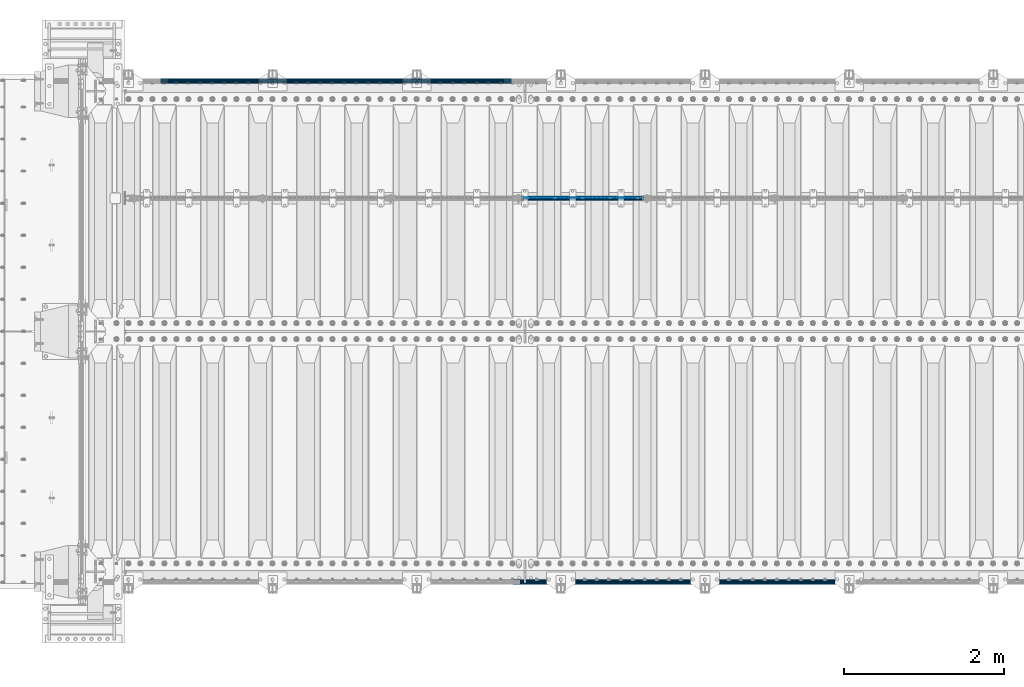
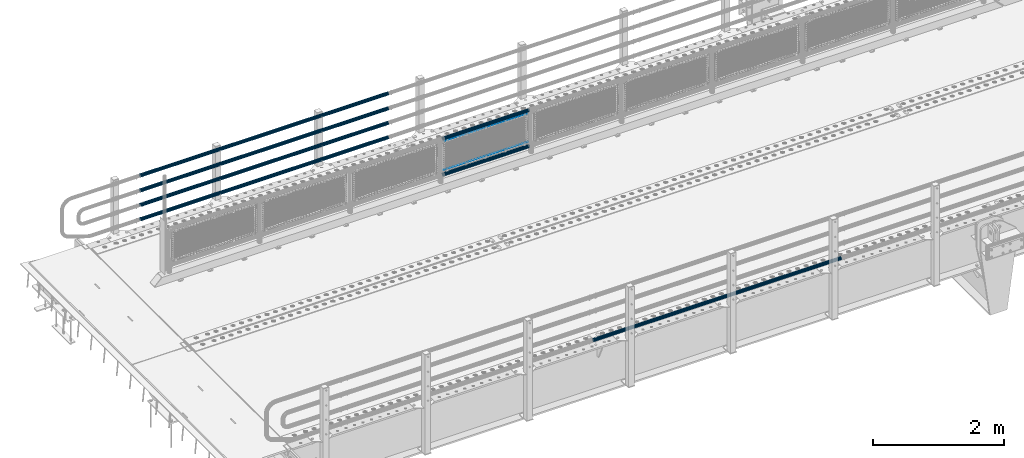
# One storey, part 97 of 208: 9 beams.
"""IFC2X3 building model written with IfcOpenShell, lengths in millimetres."""

from ifc_helpers import new_model, si_unit, frame, origin_with_axes, place, context, subcontext, project, spatial, faceted_brep, material, type_object, element, save


model = new_model("IFC2X3")

# Units and contexts
model_context = context("Model", 3, precision=1e-05, world=origin_with_axes())
body_context = subcontext(model_context, "Body", "Model", "MODEL_VIEW")
ifc_project = project(units=[si_unit("LENGTHUNIT", "METRE", prefix="MILLI"), si_unit("AREAUNIT", "SQUARE_METRE"), si_unit("VOLUMEUNIT", "CUBIC_METRE"), si_unit("MASSUNIT", "GRAM", prefix="KILO"), si_unit("TIMEUNIT", "SECOND"), si_unit("PLANEANGLEUNIT", "RADIAN"), si_unit("SOLIDANGLEUNIT", "STERADIAN"), si_unit("THERMODYNAMICTEMPERATUREUNIT", "DEGREE_CELSIUS"), si_unit("LUMINOUSINTENSITYUNIT", "LUMEN")], contexts=[model_context])

# Site, building, storey
site_placement = place(None, origin_with_axes())
site = spatial("IfcSite", under=ifc_project, at=site_placement, CompositionType="ELEMENT")
building_placement = place(site_placement, origin_with_axes())
building = spatial("IfcBuilding", under=site, at=building_placement, Name="Standard", CompositionType="ELEMENT")
storey_placement = place(building_placement, origin_with_axes())
storey = spatial("IfcBuildingStorey", under=building, at=storey_placement, Name="Undefined", CompositionType="ELEMENT", Elevation=0.0)

# Beams
ifc_material_1 = material(Name="Misc_Undefined")
beam_type_1 = type_object("IfcBeamType", Name="D3", PredefinedType="NOTDEFINED")
beam_1_placement = place(storey_placement, frame((-36974.0, 4670.5, 378.020000000001), z_axis=(0.0, 0.0, 1.0), x_axis=(1.0, 0.0, 0.0)))
element("IfcBeam", 1, at=beam_1_placement, inside=storey, type_object=beam_type_1, material=ifc_material_1, ObjectType="D3", context=body_context, shape_type="Brep", body=[
    faceted_brep([(0.0, -1.49999999999909, 3.63797880709171e-12), (-7.27595761418343e-12, -0.749999999999091, -1.29903810567669), (1490.0, -0.75, -1.29903810567669), (1490.0, -1.5, 0.0), (-3.63797880709171e-12, 0.750000000000909, -1.29903810567669), (1490.0, 0.75, -1.29903810567669), (0.0, 1.50000000000182, 3.63797880709171e-12), (1490.0, 1.5, 0.0), (-3.63797880709171e-12, 0.750000000000909, 1.29903810567669), (1490.0, 0.75, 1.29903810567669), (-7.27595761418343e-12, -0.749999999999091, 1.29903810567669), (1490.0, -0.75, 1.29903810567669)], [[[0, 1, 2, 3]], [[1, 4, 5, 2]], [[4, 6, 7, 5]], [[6, 8, 9, 7]], [[8, 10, 11, 9]], [[10, 0, 3, 11]], [[5, 7, 9, 11, 3, 2]], [[10, 8, 6, 4, 1, 0]]]),
])
beam_2_placement = place(storey_placement, frame((-36949.0, 4670.5, 913.020000000001), z_axis=(0.0, 0.0, 1.0), x_axis=(1.0, 0.0, 0.0)))
element("IfcBeam", 2, at=beam_2_placement, inside=storey, type_object=beam_type_1, material=ifc_material_1, ObjectType="D3", context=body_context, shape_type="Brep", body=[
    faceted_brep([(0.0, -1.49999999999909, 3.63797880709171e-12), (-7.27595761418343e-12, -0.749999999999091, -1.29903810567669), (1440.0, -0.75, -1.29903810567669), (1440.0, -1.5, 0.0), (-3.63797880709171e-12, 0.750000000000909, -1.29903810567669), (1440.0, 0.75, -1.29903810567663), (0.0, 1.50000000000182, 3.63797880709171e-12), (1440.0, 1.5, 0.0), (-3.63797880709171e-12, 0.750000000000909, 1.29903810567669), (1440.0, 0.75, 1.29903810567669), (-7.27595761418343e-12, -0.749999999999091, 1.29903810567669), (1440.0, -0.75, 1.29903810567669)], [[[0, 1, 2, 3]], [[1, 4, 5, 2]], [[4, 6, 7, 5]], [[6, 8, 9, 7]], [[8, 10, 11, 9]], [[10, 0, 3, 11]], [[5, 7, 9, 11, 3, 2]], [[10, 8, 6, 4, 1, 0]]]),
])
ifc_material_2 = material()
beam_type_2 = type_object("IfcBeamType", PredefinedType="NOTDEFINED")
beam_3_placement = place(storey_placement, frame((-36994.15, 4664.5, 298.170000000003), z_axis=(0.0, 0.0, 1.0), x_axis=(1.0, 0.0, 0.0)))
element("IfcBeam", 3, at=beam_3_placement, inside=storey, type_object=beam_type_2, material=ifc_material_2, context=body_context, shape_type="Brep", body=[
    faceted_brep([(0.0, -25.3500000000004, 0.0), (0.0, -23.4203461491616, 9.70102501045403), (1530.0, -23.4203461491616, 9.70102501045506), (1530.0, -25.3500000000004, 0.0), (0.0, -17.9251569030794, 17.9251569030785), (1530.0, -17.9251569030794, 17.925156903079), (0.0, -9.70102501045494, 23.4203461491597), (1530.0, -9.70102501045494, 23.4203461491611), (0.0, 0.0, 25.3499999999985), (1530.0, 0.0, 25.35), (0.0, 9.70102501045494, 23.4203461491597), (1530.0, 9.70102501045494, 23.4203461491611), (0.0, 17.9251569030794, 17.9251569030785), (1530.0, 17.9251569030794, 17.925156903079), (0.0, 23.4203461491616, 9.70102501045403), (1530.0, 23.4203461491616, 9.701025010455), (0.0, 25.3500000000004, 0.0), (1530.0, 25.3500000000004, 0.0), (0.0, 23.4203461491616, -9.70102501045403), (1530.0, 23.4203461491616, -9.70102501045506), (0.0, 17.9251569030794, -17.9251569030785), (1530.0, 17.9251569030794, -17.925156903079), (0.0, 9.70102501045494, -23.4203461491597), (1530.0, 9.70102501045494, -23.4203461491611), (0.0, 0.0, -25.3499999999985), (1530.0, 0.0, -25.35), (0.0, -9.70102501045494, -23.4203461491597), (1530.0, -9.70102501045494, -23.4203461491611), (0.0, -17.9251569030794, -17.9251569030785), (1530.0, -17.9251569030794, -17.925156903079), (0.0, -23.4203461491616, -9.70102501045403), (1530.0, -23.4203461491616, -9.701025010455), (0.0, -30.1499999999996, 0.0), (0.0, -27.8549679052148, -11.5379054858058), (1530.0, -27.8549679052148, -11.5379054858075), (1530.0, -30.1499999999996, 0.0), (0.0, -21.3192694527743, -21.3192694527752), (1530.0, -21.3192694527743, -21.3192694527744), (0.0, -11.5379054858076, -27.8549679052157), (1530.0, -11.5379054858076, -27.8549679052153), (0.0, 0.0, -30.1500000000015), (1530.0, 0.0, -30.15), (0.0, 11.5379054858076, -27.8549679052157), (1530.0, 11.5379054858076, -27.8549679052153), (0.0, 21.3192694527743, -21.3192694527752), (1530.0, 21.3192694527743, -21.3192694527744), (0.0, 27.8549679052157, -11.5379054858058), (1530.0, 27.8549679052157, -11.5379054858075), (0.0, 30.1499999999996, 0.0), (1530.0, 30.1499999999996, 0.0), (0.0, 27.8549679052157, 11.5379054858058), (1530.0, 27.8549679052157, 11.5379054858075), (0.0, 21.3192694527743, 21.3192694527752), (1530.0, 21.3192694527743, 21.3192694527744), (0.0, 11.5379054858076, 27.8549679052157), (1530.0, 11.5379054858076, 27.8549679052153), (0.0, 0.0, 30.1500000000015), (1530.0, 0.0, 30.15), (0.0, -11.5379054858076, 27.8549679052157), (1530.0, -11.5379054858076, 27.8549679052153), (0.0, -21.3192694527743, 21.3192694527752), (1530.0, -21.3192694527743, 21.3192694527744), (0.0, -27.8549679052157, 11.5379054858058), (1530.0, -27.8549679052157, 11.5379054858075)], [[[0, 1, 2, 3]], [[1, 4, 5, 2]], [[4, 6, 7, 5]], [[6, 8, 9, 7]], [[8, 10, 11, 9]], [[10, 12, 13, 11]], [[12, 14, 15, 13]], [[14, 16, 17, 15]], [[16, 18, 19, 17]], [[18, 20, 21, 19]], [[20, 22, 23, 21]], [[22, 24, 25, 23]], [[24, 26, 27, 25]], [[26, 28, 29, 27]], [[28, 30, 31, 29]], [[30, 0, 3, 31]], [[32, 33, 34, 35]], [[33, 36, 37, 34]], [[36, 38, 39, 37]], [[38, 40, 41, 39]], [[40, 42, 43, 41]], [[42, 44, 45, 43]], [[44, 46, 47, 45]], [[46, 48, 49, 47]], [[48, 50, 51, 49]], [[50, 52, 53, 51]], [[52, 54, 55, 53]], [[54, 56, 57, 55]], [[56, 58, 59, 57]], [[58, 60, 61, 59]], [[60, 62, 63, 61]], [[62, 32, 35, 63]], [[37, 39, 41, 43, 45, 47, 49, 51, 53, 55, 57, 59, 61, 63, 35, 34], [5, 7, 9, 11, 13, 15, 17, 19, 21, 23, 25, 27, 29, 31, 3, 2]], [[62, 60, 58, 56, 54, 52, 50, 48, 46, 44, 42, 40, 38, 36, 33, 32], [30, 28, 26, 24, 22, 20, 18, 16, 14, 12, 10, 8, 6, 4, 1, 0]]]),
])
beam_4_placement = place(storey_placement, frame((-36994.15, 4664.5, 969.850000000001), z_axis=(0.0, 0.0, 1.0), x_axis=(1.0, 0.0, 0.0)))
element("IfcBeam", 4, at=beam_4_placement, inside=storey, type_object=beam_type_2, material=ifc_material_2, context=body_context, shape_type="Brep", body=[
    faceted_brep([(0.0, -25.3500000000004, 0.0), (0.0, -23.4203461491616, 9.70102501045403), (1530.0, -23.4203461491616, 9.70102501045506), (1530.0, -25.3500000000004, 0.0), (0.0, -17.9251569030794, 17.9251569030785), (1530.0, -17.9251569030794, 17.925156903079), (0.0, -9.70102501045494, 23.4203461491597), (1530.0, -9.70102501045494, 23.4203461491611), (0.0, 0.0, 25.3499999999985), (1530.0, 0.0, 25.35), (0.0, 9.70102501045494, 23.4203461491597), (1530.0, 9.70102501045494, 23.4203461491611), (0.0, 17.9251569030794, 17.9251569030785), (1530.0, 17.9251569030794, 17.925156903079), (0.0, 23.4203461491616, 9.70102501045403), (1530.0, 23.4203461491616, 9.701025010455), (0.0, 25.3500000000004, 0.0), (1530.0, 25.3500000000004, 0.0), (0.0, 23.4203461491616, -9.70102501045403), (1530.0, 23.4203461491616, -9.70102501045506), (0.0, 17.9251569030794, -17.9251569030785), (1530.0, 17.9251569030794, -17.925156903079), (0.0, 9.70102501045494, -23.4203461491597), (1530.0, 9.70102501045494, -23.4203461491611), (0.0, 0.0, -25.3499999999985), (1530.0, 0.0, -25.35), (0.0, -9.70102501045494, -23.4203461491597), (1530.0, -9.70102501045494, -23.4203461491611), (0.0, -17.9251569030794, -17.9251569030785), (1530.0, -17.9251569030794, -17.925156903079), (0.0, -23.4203461491616, -9.70102501045403), (1530.0, -23.4203461491616, -9.701025010455), (0.0, -30.1499999999996, 0.0), (0.0, -27.8549679052148, -11.5379054858058), (1530.0, -27.8549679052148, -11.5379054858075), (1530.0, -30.1499999999996, 0.0), (0.0, -21.3192694527743, -21.3192694527752), (1530.0, -21.3192694527743, -21.3192694527744), (0.0, -11.5379054858076, -27.8549679052157), (1530.0, -11.5379054858076, -27.8549679052153), (0.0, 0.0, -30.1500000000015), (1530.0, 0.0, -30.15), (0.0, 11.5379054858076, -27.8549679052157), (1530.0, 11.5379054858076, -27.8549679052153), (0.0, 21.3192694527743, -21.3192694527752), (1530.0, 21.3192694527743, -21.3192694527744), (0.0, 27.8549679052157, -11.5379054858058), (1530.0, 27.8549679052157, -11.5379054858075), (0.0, 30.1499999999996, 0.0), (1530.0, 30.1499999999996, 0.0), (0.0, 27.8549679052157, 11.5379054858058), (1530.0, 27.8549679052157, 11.5379054858075), (0.0, 21.3192694527743, 21.3192694527752), (1530.0, 21.3192694527743, 21.3192694527744), (0.0, 11.5379054858076, 27.8549679052157), (1530.0, 11.5379054858076, 27.8549679052153), (0.0, 0.0, 30.1500000000015), (1530.0, 0.0, 30.15), (0.0, -11.5379054858076, 27.8549679052157), (1530.0, -11.5379054858076, 27.8549679052153), (0.0, -21.3192694527743, 21.3192694527752), (1530.0, -21.3192694527743, 21.3192694527744), (0.0, -27.8549679052157, 11.5379054858058), (1530.0, -27.8549679052157, 11.5379054858075)], [[[0, 1, 2, 3]], [[1, 4, 5, 2]], [[4, 6, 7, 5]], [[6, 8, 9, 7]], [[8, 10, 11, 9]], [[10, 12, 13, 11]], [[12, 14, 15, 13]], [[14, 16, 17, 15]], [[16, 18, 19, 17]], [[18, 20, 21, 19]], [[20, 22, 23, 21]], [[22, 24, 25, 23]], [[24, 26, 27, 25]], [[26, 28, 29, 27]], [[28, 30, 31, 29]], [[30, 0, 3, 31]], [[32, 33, 34, 35]], [[33, 36, 37, 34]], [[36, 38, 39, 37]], [[38, 40, 41, 39]], [[40, 42, 43, 41]], [[42, 44, 45, 43]], [[44, 46, 47, 45]], [[46, 48, 49, 47]], [[48, 50, 51, 49]], [[50, 52, 53, 51]], [[52, 54, 55, 53]], [[54, 56, 57, 55]], [[56, 58, 59, 57]], [[58, 60, 61, 59]], [[60, 62, 63, 61]], [[62, 32, 35, 63]], [[37, 39, 41, 43, 45, 47, 49, 51, 53, 55, 57, 59, 61, 63, 35, 34], [5, 7, 9, 11, 13, 15, 17, 19, 21, 23, 25, 27, 29, 31, 3, 2]], [[62, 60, 58, 56, 54, 52, 50, 48, 46, 44, 42, 40, 38, 36, 33, 32], [30, 28, 26, 24, 22, 20, 18, 16, 14, 12, 10, 8, 6, 4, 1, 0]]]),
])
beam_type_3 = type_object("IfcBeamType", PredefinedType="NOTDEFINED")
beam_5_placement = place(storey_placement, frame((-37116.0000000001, 6129.85000000009, 149.849999999725), z_axis=(0.0, 0.0, -1.0), x_axis=(-1.0, 0.0, 0.0)))
element("IfcBeam", 5, at=beam_5_placement, inside=storey, type_object=beam_type_3, material=ifc_material_2, context=body_context, shape_type="Brep", body=[
    faceted_brep([(0.0, -26.5500000000002, 0.0), (0.0, -24.5290015881747, 10.1602451292931), (4384.00249699992, -24.5290015881747, 10.1602451292931), (4384.00249699992, -26.5500000000002, 0.0), (0.0, -18.7736850405026, 18.7736850405028), (4384.00249699992, -18.7736850405026, 18.7736850405028), (0.0, -10.1602451292929, 24.5290015881747), (4384.00249699992, -10.1602451292929, 24.5290015881747), (0.0, 0.0, 26.55), (4384.00249699992, 0.0, 26.55), (0.0, 10.1602451292929, 24.5290015881747), (4384.00249699992, 10.1602451292929, 24.5290015881747), (0.0, 18.7736850405026, 18.7736850405028), (4384.00249699992, 18.7736850405026, 18.7736850405028), (0.0, 24.5290015881747, 10.1602451292931), (4384.00249699992, 24.5290015881747, 10.1602451292931), (0.0, 26.5500000000002, 0.0), (4384.00249699992, 26.5500000000002, 0.0), (0.0, 24.5290015881747, -10.1602451292931), (4384.00249699992, 24.5290015881747, -10.1602451292931), (0.0, 18.7736850405026, -18.7736850405028), (4384.00249699992, 18.7736850405026, -18.7736850405028), (0.0, 10.1602451292929, -24.5290015881747), (4384.00249699992, 10.1602451292929, -24.5290015881747), (0.0, 0.0, -26.55), (4384.00249699992, 0.0, -26.55), (0.0, -10.1602451292929, -24.5290015881747), (4384.00249699992, -10.1602451292929, -24.5290015881747), (0.0, -18.7736850405026, -18.7736850405028), (4384.00249699992, -18.7736850405026, -18.7736850405028), (0.0, -24.5290015881747, -10.1602451292931), (4384.00249699992, -24.5290015881747, -10.1602451292931), (0.0, -30.1499999999996, 0.0), (0.0, -27.8549679052148, -11.5379054858058), (4384.00249699992, -27.8549679052148, -11.5379054858075), (4384.00249699992, -30.1499999999996, 0.0), (0.0, -21.3192694527743, -21.3192694527752), (4384.00249699992, -21.3192694527743, -21.3192694527744), (0.0, -11.5379054858076, -27.8549679052157), (4384.00249699992, -11.5379054858076, -27.8549679052153), (0.0, 0.0, -30.1500000000015), (4384.00249699992, 0.0, -30.15), (0.0, 11.5379054858076, -27.8549679052157), (4384.00249699992, 11.5379054858076, -27.8549679052153), (0.0, 21.3192694527743, -21.3192694527752), (4384.00249699992, 21.3192694527743, -21.3192694527744), (0.0, 27.8549679052157, -11.5379054858058), (4384.00249699992, 27.8549679052157, -11.5379054858074), (0.0, 30.1499999999996, 0.0), (4384.00249699992, 30.1499999999996, 0.0), (0.0, 27.8549679052157, 11.5379054858058), (4384.00249699992, 27.8549679052157, 11.5379054858075), (0.0, 21.3192694527743, 21.3192694527752), (4384.00249699992, 21.3192694527743, 21.3192694527744), (0.0, 11.5379054858076, 27.8549679052157), (4384.00249699992, 11.5379054858076, 27.8549679052153), (0.0, 0.0, 30.1500000000015), (4384.00249699992, 0.0, 30.15), (0.0, -11.5379054858076, 27.8549679052157), (4384.00249699992, -11.5379054858076, 27.8549679052153), (0.0, -21.3192694527743, 21.3192694527752), (4384.00249699992, -21.3192694527743, 21.3192694527744), (0.0, -27.8549679052157, 11.5379054858058), (4384.00249699992, -27.8549679052157, 11.5379054858075)], [[[0, 1, 2, 3]], [[1, 4, 5, 2]], [[4, 6, 7, 5]], [[6, 8, 9, 7]], [[8, 10, 11, 9]], [[10, 12, 13, 11]], [[12, 14, 15, 13]], [[14, 16, 17, 15]], [[16, 18, 19, 17]], [[18, 20, 21, 19]], [[20, 22, 23, 21]], [[22, 24, 25, 23]], [[24, 26, 27, 25]], [[26, 28, 29, 27]], [[28, 30, 31, 29]], [[30, 0, 3, 31]], [[32, 33, 34, 35]], [[33, 36, 37, 34]], [[36, 38, 39, 37]], [[38, 40, 41, 39]], [[40, 42, 43, 41]], [[42, 44, 45, 43]], [[44, 46, 47, 45]], [[46, 48, 49, 47]], [[48, 50, 51, 49]], [[50, 52, 53, 51]], [[52, 54, 55, 53]], [[54, 56, 57, 55]], [[56, 58, 59, 57]], [[58, 60, 61, 59]], [[60, 62, 63, 61]], [[62, 32, 35, 63]], [[37, 39, 41, 43, 45, 47, 49, 51, 53, 55, 57, 59, 61, 63, 35, 34], [5, 7, 9, 11, 13, 15, 17, 19, 21, 23, 25, 27, 29, 31, 3, 2]], [[62, 60, 58, 56, 54, 52, 50, 48, 46, 44, 42, 40, 38, 36, 33, 32], [30, 28, 26, 24, 22, 20, 18, 16, 14, 12, 10, 8, 6, 4, 1, 0]]]),
])
beam_6_placement = place(storey_placement, frame((-37116.0000000001, 6129.85000000009, 420.149999999728), z_axis=(0.0, 0.0, -1.0), x_axis=(-1.0, 0.0, 0.0)))
element("IfcBeam", 6, at=beam_6_placement, inside=storey, type_object=beam_type_3, material=ifc_material_2, context=body_context, shape_type="Brep", body=[
    faceted_brep([(0.0, -26.5500000000002, 0.0), (0.0, -24.5290015881747, 10.1602451292931), (4384.00249699992, -24.5290015881747, 10.1602451292931), (4384.00249699992, -26.5500000000002, 0.0), (0.0, -18.7736850405026, 18.7736850405028), (4384.00249699992, -18.7736850405026, 18.7736850405028), (0.0, -10.1602451292929, 24.5290015881747), (4384.00249699992, -10.1602451292929, 24.5290015881747), (0.0, 0.0, 26.55), (4384.00249699992, 0.0, 26.55), (0.0, 10.1602451292929, 24.5290015881747), (4384.00249699992, 10.1602451292929, 24.5290015881747), (0.0, 18.7736850405026, 18.7736850405028), (4384.00249699992, 18.7736850405026, 18.7736850405028), (0.0, 24.5290015881747, 10.1602451292931), (4384.00249699992, 24.5290015881747, 10.1602451292931), (0.0, 26.5500000000002, 0.0), (4384.00249699992, 26.5500000000002, 0.0), (0.0, 24.5290015881747, -10.1602451292931), (4384.00249699992, 24.5290015881747, -10.1602451292931), (0.0, 18.7736850405026, -18.7736850405028), (4384.00249699992, 18.7736850405026, -18.7736850405028), (0.0, 10.1602451292929, -24.5290015881747), (4384.00249699992, 10.1602451292929, -24.5290015881747), (0.0, 0.0, -26.55), (4384.00249699992, 0.0, -26.55), (0.0, -10.1602451292929, -24.5290015881747), (4384.00249699992, -10.1602451292929, -24.5290015881747), (0.0, -18.7736850405026, -18.7736850405028), (4384.00249699992, -18.7736850405026, -18.7736850405028), (0.0, -24.5290015881747, -10.1602451292931), (4384.00249699992, -24.5290015881747, -10.1602451292931), (0.0, -30.1499999999996, 0.0), (0.0, -27.8549679052148, -11.5379054858058), (4384.00249699992, -27.8549679052148, -11.5379054858075), (4384.00249699992, -30.1499999999996, 0.0), (0.0, -21.3192694527743, -21.3192694527752), (4384.00249699992, -21.3192694527743, -21.3192694527744), (0.0, -11.5379054858076, -27.8549679052157), (4384.00249699992, -11.5379054858076, -27.8549679052153), (0.0, 0.0, -30.1500000000015), (4384.00249699992, 0.0, -30.15), (0.0, 11.5379054858076, -27.8549679052157), (4384.00249699992, 11.5379054858076, -27.8549679052153), (0.0, 21.3192694527743, -21.3192694527752), (4384.00249699992, 21.3192694527743, -21.3192694527744), (0.0, 27.8549679052157, -11.5379054858058), (4384.00249699992, 27.8549679052157, -11.5379054858074), (0.0, 30.1499999999996, 0.0), (4384.00249699992, 30.1499999999996, 0.0), (0.0, 27.8549679052157, 11.5379054858058), (4384.00249699992, 27.8549679052157, 11.5379054858075), (0.0, 21.3192694527743, 21.3192694527752), (4384.00249699992, 21.3192694527743, 21.3192694527744), (0.0, 11.5379054858076, 27.8549679052157), (4384.00249699992, 11.5379054858076, 27.8549679052153), (0.0, 0.0, 30.1500000000015), (4384.00249699992, 0.0, 30.15), (0.0, -11.5379054858076, 27.8549679052157), (4384.00249699992, -11.5379054858076, 27.8549679052153), (0.0, -21.3192694527743, 21.3192694527752), (4384.00249699992, -21.3192694527743, 21.3192694527744), (0.0, -27.8549679052157, 11.5379054858058), (4384.00249699992, -27.8549679052157, 11.5379054858075)], [[[0, 1, 2, 3]], [[1, 4, 5, 2]], [[4, 6, 7, 5]], [[6, 8, 9, 7]], [[8, 10, 11, 9]], [[10, 12, 13, 11]], [[12, 14, 15, 13]], [[14, 16, 17, 15]], [[16, 18, 19, 17]], [[18, 20, 21, 19]], [[20, 22, 23, 21]], [[22, 24, 25, 23]], [[24, 26, 27, 25]], [[26, 28, 29, 27]], [[28, 30, 31, 29]], [[30, 0, 3, 31]], [[32, 33, 34, 35]], [[33, 36, 37, 34]], [[36, 38, 39, 37]], [[38, 40, 41, 39]], [[40, 42, 43, 41]], [[42, 44, 45, 43]], [[44, 46, 47, 45]], [[46, 48, 49, 47]], [[48, 50, 51, 49]], [[50, 52, 53, 51]], [[52, 54, 55, 53]], [[54, 56, 57, 55]], [[56, 58, 59, 57]], [[58, 60, 61, 59]], [[60, 62, 63, 61]], [[62, 32, 35, 63]], [[37, 39, 41, 43, 45, 47, 49, 51, 53, 55, 57, 59, 61, 63, 35, 34], [5, 7, 9, 11, 13, 15, 17, 19, 21, 23, 25, 27, 29, 31, 3, 2]], [[62, 60, 58, 56, 54, 52, 50, 48, 46, 44, 42, 40, 38, 36, 33, 32], [30, 28, 26, 24, 22, 20, 18, 16, 14, 12, 10, 8, 6, 4, 1, 0]]]),
])
beam_7_placement = place(storey_placement, frame((-37116.0000000001, 6129.85000000009, 969.849999999725), z_axis=(0.0, 0.0, -1.0), x_axis=(-1.0, 0.0, 0.0)))
element("IfcBeam", 7, at=beam_7_placement, inside=storey, type_object=beam_type_3, material=ifc_material_2, context=body_context, shape_type="Brep", body=[
    faceted_brep([(0.0, -26.5500000000002, 0.0), (0.0, -24.5290015881747, 10.1602451292931), (4384.00249699992, -24.5290015881747, 10.1602451292931), (4384.00249699992, -26.5500000000002, 0.0), (0.0, -18.7736850405026, 18.7736850405028), (4384.00249699992, -18.7736850405026, 18.7736850405028), (0.0, -10.1602451292929, 24.5290015881747), (4384.00249699992, -10.1602451292929, 24.5290015881747), (0.0, 0.0, 26.55), (4384.00249699992, 0.0, 26.55), (0.0, 10.1602451292929, 24.5290015881747), (4384.00249699992, 10.1602451292929, 24.5290015881747), (0.0, 18.7736850405026, 18.7736850405028), (4384.00249699992, 18.7736850405026, 18.7736850405028), (0.0, 24.5290015881747, 10.1602451292931), (4384.00249699992, 24.5290015881747, 10.1602451292931), (0.0, 26.5500000000002, 0.0), (4384.00249699992, 26.5500000000002, 0.0), (0.0, 24.5290015881747, -10.1602451292931), (4384.00249699992, 24.5290015881747, -10.1602451292931), (0.0, 18.7736850405026, -18.7736850405028), (4384.00249699992, 18.7736850405026, -18.7736850405028), (0.0, 10.1602451292929, -24.5290015881747), (4384.00249699992, 10.1602451292929, -24.5290015881747), (0.0, 0.0, -26.55), (4384.00249699992, 0.0, -26.55), (0.0, -10.1602451292929, -24.5290015881747), (4384.00249699992, -10.1602451292929, -24.5290015881747), (0.0, -18.7736850405026, -18.7736850405028), (4384.00249699992, -18.7736850405026, -18.7736850405028), (0.0, -24.5290015881747, -10.1602451292931), (4384.00249699992, -24.5290015881747, -10.1602451292931), (0.0, -30.1499999999996, 0.0), (0.0, -27.8549679052148, -11.5379054858058), (4384.00249699992, -27.8549679052148, -11.5379054858075), (4384.00249699992, -30.1499999999996, 0.0), (0.0, -21.3192694527743, -21.3192694527752), (4384.00249699992, -21.3192694527743, -21.3192694527744), (0.0, -11.5379054858076, -27.8549679052157), (4384.00249699992, -11.5379054858076, -27.8549679052153), (0.0, 0.0, -30.1500000000015), (4384.00249699992, 0.0, -30.15), (0.0, 11.5379054858076, -27.8549679052157), (4384.00249699992, 11.5379054858076, -27.8549679052153), (0.0, 21.3192694527743, -21.3192694527752), (4384.00249699992, 21.3192694527743, -21.3192694527744), (0.0, 27.8549679052157, -11.5379054858058), (4384.00249699992, 27.8549679052157, -11.5379054858074), (0.0, 30.1499999999996, 0.0), (4384.00249699992, 30.1499999999996, 0.0), (0.0, 27.8549679052157, 11.5379054858058), (4384.00249699992, 27.8549679052157, 11.5379054858075), (0.0, 21.3192694527743, 21.3192694527752), (4384.00249699992, 21.3192694527743, 21.3192694527744), (0.0, 11.5379054858076, 27.8549679052157), (4384.00249699992, 11.5379054858076, 27.8549679052153), (0.0, 0.0, 30.1500000000015), (4384.00249699992, 0.0, 30.15), (0.0, -11.5379054858076, 27.8549679052157), (4384.00249699992, -11.5379054858076, 27.8549679052153), (0.0, -21.3192694527743, 21.3192694527752), (4384.00249699992, -21.3192694527743, 21.3192694527744), (0.0, -27.8549679052157, 11.5379054858058), (4384.00249699992, -27.8549679052157, 11.5379054858075)], [[[0, 1, 2, 3]], [[1, 4, 5, 2]], [[4, 6, 7, 5]], [[6, 8, 9, 7]], [[8, 10, 11, 9]], [[10, 12, 13, 11]], [[12, 14, 15, 13]], [[14, 16, 17, 15]], [[16, 18, 19, 17]], [[18, 20, 21, 19]], [[20, 22, 23, 21]], [[22, 24, 25, 23]], [[24, 26, 27, 25]], [[26, 28, 29, 27]], [[28, 30, 31, 29]], [[30, 0, 3, 31]], [[32, 33, 34, 35]], [[33, 36, 37, 34]], [[36, 38, 39, 37]], [[38, 40, 41, 39]], [[40, 42, 43, 41]], [[42, 44, 45, 43]], [[44, 46, 47, 45]], [[46, 48, 49, 47]], [[48, 50, 51, 49]], [[50, 52, 53, 51]], [[52, 54, 55, 53]], [[54, 56, 57, 55]], [[56, 58, 59, 57]], [[58, 60, 61, 59]], [[60, 62, 63, 61]], [[62, 32, 35, 63]], [[37, 39, 41, 43, 45, 47, 49, 51, 53, 55, 57, 59, 61, 63, 35, 34], [5, 7, 9, 11, 13, 15, 17, 19, 21, 23, 25, 27, 29, 31, 3, 2]], [[62, 60, 58, 56, 54, 52, 50, 48, 46, 44, 42, 40, 38, 36, 33, 32], [30, 28, 26, 24, 22, 20, 18, 16, 14, 12, 10, 8, 6, 4, 1, 0]]]),
])
beam_8_placement = place(storey_placement, frame((-37116.0000000001, 6129.85000000009, 689.849999999725), z_axis=(0.0, 0.0, -1.0), x_axis=(-1.0, 0.0, 0.0)))
element("IfcBeam", 8, at=beam_8_placement, inside=storey, type_object=beam_type_3, material=ifc_material_2, context=body_context, shape_type="Brep", body=[
    faceted_brep([(0.0, -26.5500000000002, 0.0), (0.0, -24.5290015881747, 10.1602451292931), (4384.00249699992, -24.5290015881747, 10.1602451292931), (4384.00249699992, -26.5500000000002, 0.0), (0.0, -18.7736850405026, 18.7736850405028), (4384.00249699992, -18.7736850405026, 18.7736850405028), (0.0, -10.1602451292929, 24.5290015881747), (4384.00249699992, -10.1602451292929, 24.5290015881747), (0.0, 0.0, 26.55), (4384.00249699992, 0.0, 26.55), (0.0, 10.1602451292929, 24.5290015881747), (4384.00249699992, 10.1602451292929, 24.5290015881747), (0.0, 18.7736850405026, 18.7736850405028), (4384.00249699992, 18.7736850405026, 18.7736850405028), (0.0, 24.5290015881747, 10.1602451292931), (4384.00249699992, 24.5290015881747, 10.1602451292931), (0.0, 26.5500000000002, 0.0), (4384.00249699992, 26.5500000000002, 0.0), (0.0, 24.5290015881747, -10.1602451292931), (4384.00249699992, 24.5290015881747, -10.1602451292931), (0.0, 18.7736850405026, -18.7736850405028), (4384.00249699992, 18.7736850405026, -18.7736850405028), (0.0, 10.1602451292929, -24.5290015881747), (4384.00249699992, 10.1602451292929, -24.5290015881747), (0.0, 0.0, -26.55), (4384.00249699992, 0.0, -26.55), (0.0, -10.1602451292929, -24.5290015881747), (4384.00249699992, -10.1602451292929, -24.5290015881747), (0.0, -18.7736850405026, -18.7736850405028), (4384.00249699992, -18.7736850405026, -18.7736850405028), (0.0, -24.5290015881747, -10.1602451292931), (4384.00249699992, -24.5290015881747, -10.1602451292931), (0.0, -30.1499999999996, 0.0), (0.0, -27.8549679052148, -11.5379054858058), (4384.00249699992, -27.8549679052148, -11.5379054858075), (4384.00249699992, -30.1499999999996, 0.0), (0.0, -21.3192694527743, -21.3192694527752), (4384.00249699992, -21.3192694527743, -21.3192694527744), (0.0, -11.5379054858076, -27.8549679052157), (4384.00249699992, -11.5379054858076, -27.8549679052153), (0.0, 0.0, -30.1500000000015), (4384.00249699992, 0.0, -30.15), (0.0, 11.5379054858076, -27.8549679052157), (4384.00249699992, 11.5379054858076, -27.8549679052153), (0.0, 21.3192694527743, -21.3192694527752), (4384.00249699992, 21.3192694527743, -21.3192694527744), (0.0, 27.8549679052157, -11.5379054858058), (4384.00249699992, 27.8549679052157, -11.5379054858074), (0.0, 30.1499999999996, 0.0), (4384.00249699992, 30.1499999999996, 0.0), (0.0, 27.8549679052157, 11.5379054858058), (4384.00249699992, 27.8549679052157, 11.5379054858075), (0.0, 21.3192694527743, 21.3192694527752), (4384.00249699992, 21.3192694527743, 21.3192694527744), (0.0, 11.5379054858076, 27.8549679052157), (4384.00249699992, 11.5379054858076, 27.8549679052153), (0.0, 0.0, 30.1500000000015), (4384.00249699992, 0.0, 30.15), (0.0, -11.5379054858076, 27.8549679052157), (4384.00249699992, -11.5379054858076, 27.8549679052153), (0.0, -21.3192694527743, 21.3192694527752), (4384.00249699992, -21.3192694527743, 21.3192694527744), (0.0, -27.8549679052157, 11.5379054858058), (4384.00249699992, -27.8549679052157, 11.5379054858075)], [[[0, 1, 2, 3]], [[1, 4, 5, 2]], [[4, 6, 7, 5]], [[6, 8, 9, 7]], [[8, 10, 11, 9]], [[10, 12, 13, 11]], [[12, 14, 15, 13]], [[14, 16, 17, 15]], [[16, 18, 19, 17]], [[18, 20, 21, 19]], [[20, 22, 23, 21]], [[22, 24, 25, 23]], [[24, 26, 27, 25]], [[26, 28, 29, 27]], [[28, 30, 31, 29]], [[30, 0, 3, 31]], [[32, 33, 34, 35]], [[33, 36, 37, 34]], [[36, 38, 39, 37]], [[38, 40, 41, 39]], [[40, 42, 43, 41]], [[42, 44, 45, 43]], [[44, 46, 47, 45]], [[46, 48, 49, 47]], [[48, 50, 51, 49]], [[50, 52, 53, 51]], [[52, 54, 55, 53]], [[54, 56, 57, 55]], [[56, 58, 59, 57]], [[58, 60, 61, 59]], [[60, 62, 63, 61]], [[62, 32, 35, 63]], [[37, 39, 41, 43, 45, 47, 49, 51, 53, 55, 57, 59, 61, 63, 35, 34], [5, 7, 9, 11, 13, 15, 17, 19, 21, 23, 25, 27, 29, 31, 3, 2]], [[62, 60, 58, 56, 54, 52, 50, 48, 46, 44, 42, 40, 38, 36, 33, 32], [30, 28, 26, 24, 22, 20, 18, 16, 14, 12, 10, 8, 6, 4, 1, 0]]]),
])
beam_9_placement = place(storey_placement, frame((-32722.0000000001, -129.849999999907, 149.849999999725), z_axis=(0.0, 0.0, -1.0), x_axis=(-1.0, 0.0, 0.0)))
element("IfcBeam", 9, at=beam_9_placement, inside=storey, type_object=beam_type_3, material=ifc_material_2, context=body_context, shape_type="Brep", body=[
    faceted_brep([(0.0, -26.5500000000002, 0.0), (0.0, -24.5290015881747, 10.1602451292931), (4384.00249699992, -24.5290015881747, 10.1602451292931), (4384.00249699992, -26.5500000000002, 0.0), (0.0, -18.7736850405026, 18.7736850405028), (4384.00249699992, -18.7736850405026, 18.7736850405028), (0.0, -10.1602451292929, 24.5290015881747), (4384.00249699992, -10.1602451292929, 24.5290015881747), (0.0, 0.0, 26.55), (4384.00249699992, 0.0, 26.55), (0.0, 10.1602451292929, 24.5290015881747), (4384.00249699992, 10.1602451292929, 24.5290015881747), (0.0, 18.7736850405026, 18.7736850405028), (4384.00249699992, 18.7736850405026, 18.7736850405028), (0.0, 24.5290015881747, 10.1602451292931), (4384.00249699992, 24.5290015881747, 10.1602451292931), (0.0, 26.5500000000002, 0.0), (4384.00249699992, 26.5500000000002, 0.0), (0.0, 24.5290015881747, -10.1602451292931), (4384.00249699992, 24.5290015881747, -10.1602451292931), (0.0, 18.7736850405026, -18.7736850405028), (4384.00249699992, 18.7736850405026, -18.7736850405028), (0.0, 10.1602451292929, -24.5290015881747), (4384.00249699992, 10.1602451292929, -24.5290015881747), (0.0, 0.0, -26.55), (4384.00249699992, 0.0, -26.55), (0.0, -10.1602451292929, -24.5290015881747), (4384.00249699992, -10.1602451292929, -24.5290015881747), (0.0, -18.7736850405026, -18.7736850405028), (4384.00249699992, -18.7736850405026, -18.7736850405028), (0.0, -24.5290015881747, -10.1602451292931), (4384.00249699992, -24.5290015881747, -10.1602451292931), (0.0, -30.1499999999996, 0.0), (0.0, -27.8549679052148, -11.5379054858058), (4384.00249699992, -27.8549679052148, -11.5379054858075), (4384.00249699992, -30.1499999999996, 0.0), (0.0, -21.3192694527743, -21.3192694527752), (4384.00249699992, -21.3192694527743, -21.3192694527744), (0.0, -11.5379054858076, -27.8549679052157), (4384.00249699992, -11.5379054858076, -27.8549679052153), (0.0, 0.0, -30.1500000000015), (4384.00249699992, 0.0, -30.15), (0.0, 11.5379054858076, -27.8549679052157), (4384.00249699992, 11.5379054858076, -27.8549679052153), (0.0, 21.3192694527743, -21.3192694527752), (4384.00249699992, 21.3192694527743, -21.3192694527744), (0.0, 27.8549679052157, -11.5379054858058), (4384.00249699992, 27.8549679052157, -11.5379054858074), (0.0, 30.1499999999996, 0.0), (4384.00249699992, 30.1499999999996, 0.0), (0.0, 27.8549679052157, 11.5379054858058), (4384.00249699992, 27.8549679052157, 11.5379054858075), (0.0, 21.3192694527743, 21.3192694527752), (4384.00249699992, 21.3192694527743, 21.3192694527744), (0.0, 11.5379054858076, 27.8549679052157), (4384.00249699992, 11.5379054858076, 27.8549679052153), (0.0, 0.0, 30.1500000000015), (4384.00249699992, 0.0, 30.15), (0.0, -11.5379054858076, 27.8549679052157), (4384.00249699992, -11.5379054858076, 27.8549679052153), (0.0, -21.3192694527743, 21.3192694527752), (4384.00249699992, -21.3192694527743, 21.3192694527744), (0.0, -27.8549679052157, 11.5379054858058), (4384.00249699992, -27.8549679052157, 11.5379054858075)], [[[0, 1, 2, 3]], [[1, 4, 5, 2]], [[4, 6, 7, 5]], [[6, 8, 9, 7]], [[8, 10, 11, 9]], [[10, 12, 13, 11]], [[12, 14, 15, 13]], [[14, 16, 17, 15]], [[16, 18, 19, 17]], [[18, 20, 21, 19]], [[20, 22, 23, 21]], [[22, 24, 25, 23]], [[24, 26, 27, 25]], [[26, 28, 29, 27]], [[28, 30, 31, 29]], [[30, 0, 3, 31]], [[32, 33, 34, 35]], [[33, 36, 37, 34]], [[36, 38, 39, 37]], [[38, 40, 41, 39]], [[40, 42, 43, 41]], [[42, 44, 45, 43]], [[44, 46, 47, 45]], [[46, 48, 49, 47]], [[48, 50, 51, 49]], [[50, 52, 53, 51]], [[52, 54, 55, 53]], [[54, 56, 57, 55]], [[56, 58, 59, 57]], [[58, 60, 61, 59]], [[60, 62, 63, 61]], [[62, 32, 35, 63]], [[37, 39, 41, 43, 45, 47, 49, 51, 53, 55, 57, 59, 61, 63, 35, 34], [5, 7, 9, 11, 13, 15, 17, 19, 21, 23, 25, 27, 29, 31, 3, 2]], [[62, 60, 58, 56, 54, 52, 50, 48, 46, 44, 42, 40, 38, 36, 33, 32], [30, 28, 26, 24, 22, 20, 18, 16, 14, 12, 10, 8, 6, 4, 1, 0]]]),
])

save(model, "model.ifc")
